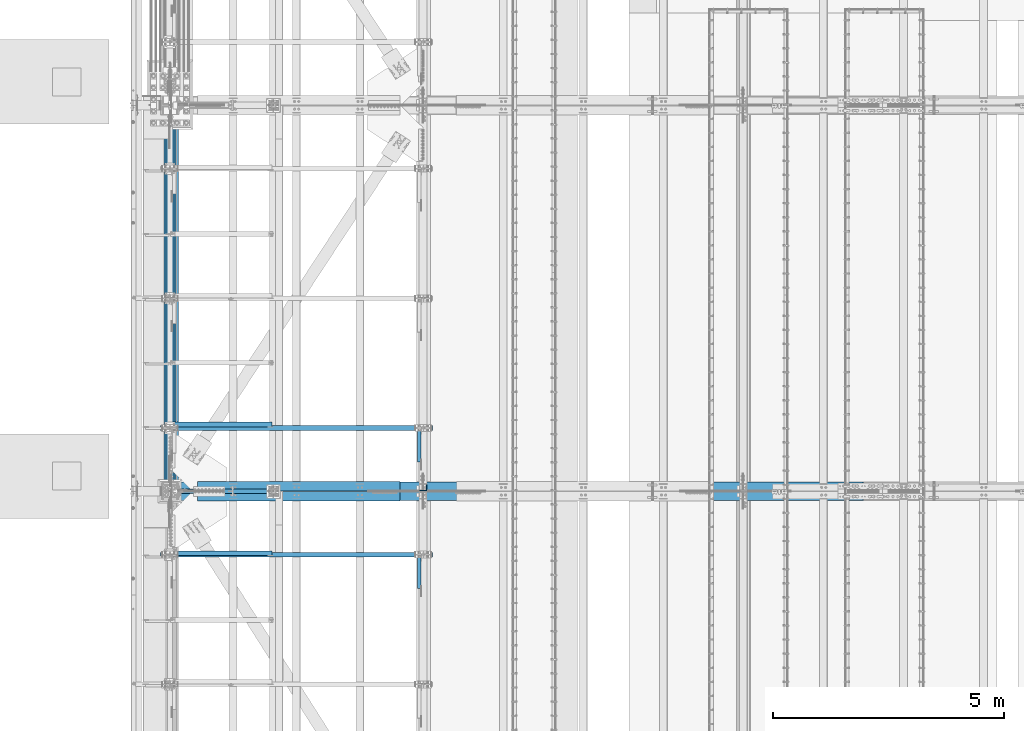
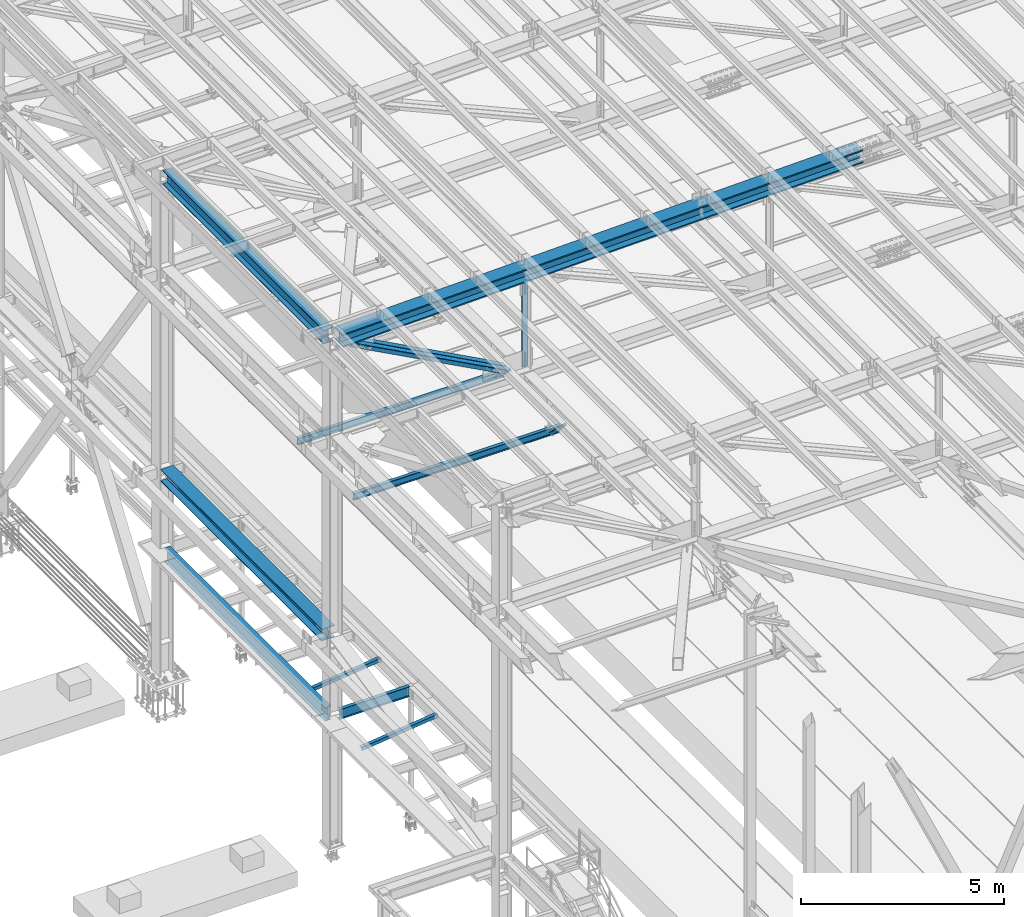
# One storey, part 1809 of 3843: 10 beams, 4 members, 14 elements without a shape of their own.
"""IFC2X3 building model written with IfcOpenShell, lengths in millimetres."""

from ifc_helpers import new_model, si_unit, frame, origin_with_axes, place, context, subcontext, project, spatial, faceted_brep, material, type_object, element, aggregate, save


model = new_model("IFC2X3")

# Units and contexts
model_context = context("Model", 3, precision=1e-05, world=origin_with_axes())
body_context = subcontext(model_context, "Body", "Model", "MODEL_VIEW")
ifc_project = project(units=[si_unit("LENGTHUNIT", "METRE", prefix="MILLI"), si_unit("AREAUNIT", "SQUARE_METRE"), si_unit("VOLUMEUNIT", "CUBIC_METRE"), si_unit("MASSUNIT", "GRAM", prefix="KILO"), si_unit("TIMEUNIT", "SECOND"), si_unit("PLANEANGLEUNIT", "RADIAN"), si_unit("SOLIDANGLEUNIT", "STERADIAN"), si_unit("THERMODYNAMICTEMPERATUREUNIT", "DEGREE_CELSIUS"), si_unit("LUMINOUSINTENSITYUNIT", "LUMEN")], contexts=[model_context])

# Site, building, storey
site_placement = place(None, origin_with_axes())
site = spatial("IfcSite", under=ifc_project, at=site_placement, CompositionType="ELEMENT")
building_placement = place(site_placement, origin_with_axes())
building = spatial("IfcBuilding", under=site, at=building_placement, Name="Undefined", CompositionType="ELEMENT")
storey_placement = place(building_placement, origin_with_axes())
storey = spatial("IfcBuildingStorey", under=building, at=storey_placement, Name="Undefined", CompositionType="ELEMENT", Elevation=0.0)

# Assembly, beam
assembly_1_placement = place(storey_placement, origin_with_axes())
assembly_1 = element("IfcElementAssembly", 1, at=assembly_1_placement, inside=storey, Name="ANGLE", AssemblyPlace="NOTDEFINED", PredefinedType="RIGID_FRAME")
ifc_material_1 = material(Name="STEEL/A572-50")
beam_type_1 = type_object("IfcBeamType", Name="L4X4X3/8", PredefinedType="NOTDEFINED")
beam_1_placement = place(assembly_1_placement, frame((38788.5093206542, 40863.341406, 33960.1419503901), z_axis=(0.0, 1.0, 0.0), x_axis=(-0.993268693078032, 0.0, -0.115833084009098)))
beam_1 = element("IfcBeam", 2, at=beam_1_placement, type_object=beam_type_1, material=ifc_material_1, Name="ANGLE", ObjectType="L4X4X3/8", context=body_context, shape_type="Brep", body=[
    faceted_brep([(0.0, 50.8000000000029, -50.8000000000029), (0.0, 50.8000000000029, 50.8000000000029), (2192.8104802954, 50.7999999940694, 50.8000000000029), (2192.8104802954, 50.7999999940694, -50.8000000000029), (0.0, 41.2750000000015, 50.8000000000029), (2192.81048029537, 41.2749999940788, 50.8000000000029), (0.0, 41.2749999999942, -41.2750000000015), (2192.81048029537, 41.2749999940788, -41.2750000000015), (0.0, -50.8000000000029, -41.2750000000015), (2192.81048029512, -50.8000000058528, -41.2750000000015), (0.0, -50.8000000000029, -50.8000000000029), (2192.81048029512, -50.8000000058528, -50.8000000000029)], [[[0, 1, 2, 3]], [[1, 4, 5, 2]], [[4, 6, 7, 5]], [[6, 8, 9, 7]], [[8, 10, 11, 9]], [[10, 0, 3, 11]], [[5, 7, 9, 11, 3, 2]], [[10, 8, 6, 4, 1, 0]]]),
])
aggregate(assembly_1, [beam_1])

assembly_2_placement = place(storey_placement, origin_with_axes())
assembly_2 = element("IfcElementAssembly", 3, at=assembly_2_placement, inside=storey, Name="ANGLE", AssemblyPlace="NOTDEFINED", PredefinedType="RIGID_FRAME")
beam_2_placement = place(assembly_2_placement, frame((38788.5093206542, 43648.808594, 33960.1419503901), z_axis=(0.0, 1.0, 0.0), x_axis=(-0.993268693078032, 0.0, -0.115833084009098)))
beam_2 = element("IfcBeam", 4, at=beam_2_placement, type_object=beam_type_1, material=ifc_material_1, Name="ANGLE", ObjectType="L4X4X3/8", context=body_context, shape_type="Brep", body=[
    faceted_brep([(0.0, 50.8000000000029, -50.8000000000029), (0.0, 50.8000000000029, 50.8000000000029), (2192.8104802954, 50.7999999940694, 50.8000000000029), (2192.8104802954, 50.7999999940694, -50.8000000000029), (0.0, 41.2750000000015, 50.8000000000029), (2192.81048029537, 41.2749999940788, 50.8000000000029), (0.0, 41.2749999999942, -41.2750000000015), (2192.81048029537, 41.2749999940788, -41.2750000000015), (0.0, -50.8000000000029, -41.2750000000015), (2192.81048029512, -50.8000000058528, -41.2750000000015), (0.0, -50.8000000000029, -50.8000000000029), (2192.81048029512, -50.8000000058528, -50.8000000000029)], [[[0, 1, 2, 3]], [[1, 4, 5, 2]], [[4, 6, 7, 5]], [[6, 8, 9, 7]], [[8, 10, 11, 9]], [[10, 0, 3, 11]], [[5, 7, 9, 11, 3, 2]], [[10, 8, 6, 4, 1, 0]]]),
])
aggregate(assembly_2, [beam_2])

# Assembly, member
assembly_3_placement = place(storey_placement, origin_with_axes())
assembly_3 = element("IfcElementAssembly", 5, at=assembly_3_placement, inside=storey, Name="ANGLE", AssemblyPlace="NOTDEFINED", PredefinedType="RIGID_FRAME")
member_type_1 = type_object("IfcMemberType", Name="L3X3X1/4", PredefinedType="NOTDEFINED")
member_1_placement = place(assembly_3_placement, frame((41973.5, 39860.4569280365, 42270.4430719635), z_axis=(0.0, -0.707106781186548, -0.707106781186548), x_axis=(5.70000238222118e-08, 0.707106781186546, -0.707106781186546)))
member_1 = element("IfcMember", 6, at=member_1_placement, type_object=member_type_1, material=ifc_material_1, Name="ANGLE", ObjectType="L3X3X1/4", context=body_context, shape_type="Brep", body=[
    faceted_brep([(1288.84678778952, -38.0999999999985, -31.7499999999272), (1288.84678778953, -38.0999999999985, -38.0999999999112), (1288.84678778953, 38.0999999999985, -38.0999999999112), (1288.84678778952, 38.0999999999985, 38.099999999904), (1288.84678778952, 31.75, 38.099999999904), (1288.84678778952, 31.75, -31.7499999999272), (298.246787789525, 31.75, 38.099999999904), (298.246787789525, 31.75, -31.7499999999272), (298.246787789525, -38.0999999999985, -31.7499999999272), (298.246787789521, -38.0999999999985, -38.0999999999112), (298.246787789521, 38.0999999999985, -38.0999999999112), (298.246787789525, 38.0999999999985, 38.099999999904)], [[[0, 1, 2, 3, 4, 5]], [[5, 4, 6, 7]], [[0, 5, 7, 8]], [[1, 0, 8, 9]], [[2, 1, 9, 10]], [[3, 2, 10, 11]], [[4, 3, 11, 6]], [[10, 9, 8, 7, 6, 11]]]),
])
aggregate(assembly_3, [member_1])

assembly_4_placement = place(storey_placement, origin_with_axes())
assembly_4 = element("IfcElementAssembly", 7, at=assembly_4_placement, inside=storey, Name="ANGLE", AssemblyPlace="NOTDEFINED", PredefinedType="RIGID_FRAME")
member_2_placement = place(assembly_4_placement, frame((41973.5, 42576.5293455559, 42297.5706544441), z_axis=(0.0, -0.707106781186548, -0.707106781186548), x_axis=(5.70000238222118e-08, 0.707106781186546, -0.707106781186546)))
member_2 = element("IfcMember", 8, at=member_2_placement, type_object=member_type_1, material=ifc_material_1, Name="ANGLE", ObjectType="L3X3X1/4", context=body_context, shape_type="Brep", body=[
    faceted_brep([(1327.21098284778, -38.0999999999985, -31.74999999992), (1327.21098284778, -38.0999999999985, -38.0999999999112), (1327.21098284778, 38.0999999999985, -38.0999999999112), (1327.21098284777, 38.0999999999985, 38.0999999999112), (1327.21098284777, 31.75, 38.0999999999112), (1327.21098284778, 31.75, -31.74999999992), (336.610982847711, 31.75, 38.0999999999112), (336.610982847719, 31.75, -31.74999999992), (336.610982847719, -38.0999999999985, -31.74999999992), (336.610982847715, -38.0999999999985, -38.099999999904), (336.610982847715, 38.0999999999985, -38.099999999904), (336.610982847711, 38.0999999999985, 38.0999999999112)], [[[0, 1, 2, 3, 4, 5]], [[5, 4, 6, 7]], [[0, 5, 7, 8]], [[1, 0, 8, 9]], [[2, 1, 9, 10]], [[3, 2, 10, 11]], [[4, 3, 11, 6]], [[10, 9, 8, 7, 6, 11]]]),
])
aggregate(assembly_4, [member_2])

# Assembly, beam
assembly_5_placement = place(storey_placement, origin_with_axes())
assembly_5 = element("IfcElementAssembly", 9, at=assembly_5_placement, inside=storey, Name="BEAM", AssemblyPlace="NOTDEFINED", PredefinedType="RIGID_FRAME")
ifc_material_2 = material(Name="STEEL/A992")
beam_type_2 = type_object("IfcBeamType", Name="W8X13", PredefinedType="NOTDEFINED")
beam_3_placement = place(assembly_5_placement, frame((36372.8, 40830.5, 41402.0), z_axis=(0.0, 0.0, 1.0), x_axis=(1.0, 0.0, 0.0)))
beam_3 = element("IfcBeam", 10, at=beam_3_placement, type_object=beam_type_2, material=ifc_material_2, Name="BEAM", ObjectType="W8X13", context=body_context, shape_type="Brep", body=[
    faceted_brep([(0.0, 50.7999999999993, -101.599999999999), (0.0, 50.7999999999993, -95.25), (5892.8, 50.7999999999993, -95.25), (5892.8, 50.7999999999993, -101.599999999999), (0.0, 3.17499999999927, -95.25), (5892.8, 3.17499999999927, -95.25), (-2.44140610448085e-05, 3.17500000000291, 95.2499999999927), (5892.8, 3.17499999999927, 95.25), (0.0, 50.7999999999993, 95.25), (5892.8, 50.7999999999993, 95.25), (0.0, 50.7999999999993, 101.599999999999), (5892.8, 50.7999999999993, 101.599999999999), (0.0, -50.7999999999993, 101.599999999999), (5892.8, -50.7999999999993, 101.599999999999), (0.0, -50.7999999999993, 95.25), (5892.8, -50.7999999999993, 95.25), (0.0, -3.17499999999927, 95.25), (5892.8, -3.17499999999927, 95.25), (0.0, -3.17499999999927, -95.25), (5892.8, -3.17499999999927, -95.25), (0.0, -50.7999999999993, -95.25), (5892.8, -50.7999999999993, -95.25), (0.0, -50.7999999999993, -101.599999999999), (5892.8, -50.7999999999993, -101.599999999999)], [[[0, 1, 2, 3]], [[1, 4, 5, 2]], [[4, 6, 7, 5]], [[6, 8, 9, 7]], [[8, 10, 11, 9]], [[10, 12, 13, 11]], [[12, 14, 15, 13]], [[14, 16, 17, 15]], [[16, 18, 19, 17]], [[18, 20, 21, 19]], [[20, 22, 23, 21]], [[22, 0, 3, 23]], [[5, 7, 9, 11, 13, 15, 17, 19, 21, 23, 3, 2]], [[22, 20, 18, 16, 14, 12, 10, 8, 6, 4, 1, 0]]]),
])
aggregate(assembly_5, [beam_3])

assembly_6_placement = place(storey_placement, origin_with_axes())
assembly_6 = element("IfcElementAssembly", 11, at=assembly_6_placement, inside=storey, Name="BEAM", AssemblyPlace="NOTDEFINED", PredefinedType="RIGID_FRAME")
beam_4_placement = place(assembly_6_placement, frame((36372.8, 43573.7, 41402.0), z_axis=(0.0, 0.0, 1.0), x_axis=(1.0, 0.0, 0.0)))
beam_4 = element("IfcBeam", 12, at=beam_4_placement, type_object=beam_type_2, material=ifc_material_2, Name="BEAM", ObjectType="W8X13", context=body_context, shape_type="Brep", body=[
    faceted_brep([(0.0, 50.7999999999993, -101.599999999999), (0.0, 50.7999999999993, -95.25), (5892.8, 50.7999999999993, -95.25), (5892.8, 50.7999999999993, -101.599999999999), (0.0, 3.17499999999927, -95.25), (5892.8, 3.17499999999927, -95.25), (-2.44140610448085e-05, 3.17500000000291, 95.2499999999927), (5892.8, 3.17499999999927, 95.25), (0.0, 50.7999999999993, 95.25), (5892.8, 50.7999999999993, 95.25), (0.0, 50.7999999999993, 101.599999999999), (5892.8, 50.7999999999993, 101.599999999999), (0.0, -50.7999999999993, 101.599999999999), (5892.8, -50.7999999999993, 101.599999999999), (0.0, -50.7999999999993, 95.25), (5892.8, -50.7999999999993, 95.25), (0.0, -3.17499999999927, 95.25), (5892.8, -3.17499999999927, 95.25), (0.0, -3.17499999999927, -95.25), (5892.8, -3.17499999999927, -95.25), (0.0, -50.7999999999993, -95.25), (5892.8, -50.7999999999993, -95.25), (0.0, -50.7999999999993, -101.599999999999), (5892.8, -50.7999999999993, -101.599999999999)], [[[0, 1, 2, 3]], [[1, 4, 5, 2]], [[4, 6, 7, 5]], [[6, 8, 9, 7]], [[8, 10, 11, 9]], [[10, 12, 13, 11]], [[12, 14, 15, 13]], [[14, 16, 17, 15]], [[16, 18, 19, 17]], [[18, 20, 21, 19]], [[20, 22, 23, 21]], [[22, 0, 3, 23]], [[5, 7, 9, 11, 13, 15, 17, 19, 21, 23, 3, 2]], [[22, 20, 18, 16, 14, 12, 10, 8, 6, 4, 1, 0]]]),
])
aggregate(assembly_6, [beam_4])

assembly_7_placement = place(storey_placement, origin_with_axes())
assembly_7 = element("IfcElementAssembly", 13, at=assembly_7_placement, inside=storey, Name="BEAM", AssemblyPlace="NOTDEFINED", PredefinedType="RIGID_FRAME")
beam_type_3 = type_object("IfcBeamType", Name="W14X193", PredefinedType="NOTDEFINED")
beam_5_placement = place(assembly_7_placement, frame((36581.1927673553, 42202.1, 45221.5968545871), z_axis=(-0.0251104770065213, 0.0, 0.999684682259614), x_axis=(0.99968468698203, 0.0, 0.0251102889995484)))
beam_5 = element("IfcBeam", 14, at=beam_5_placement, type_object=beam_type_3, material=ifc_material_2, Name="BEAM", ObjectType="W14X193", context=body_context, shape_type="Brep", body=[
    faceted_brep([(12012.6309710702, 11.1125000000029, 163.391995177728), (12012.6309710702, 200.025000000001, 163.391995177728), (13514.2350328195, 200.025000000001, 162.055596753664), (13514.2350328195, 11.1125000000029, 162.055596753664), (10511.0266180469, 11.1125000000029, 164.346565542677), (10511.0266180469, 200.025000000001, 164.346565542677), (9009.42207084113, 11.1125000000029, 164.919307789831), (9009.42207084113, 200.025000000001, 164.919307789831), (7507.81742654402, 11.1125000000029, 165.110221879142), (7507.81742654402, 200.025000000001, 165.110221879142), (6006.21278224691, 11.1125000000029, 164.919307800374), (6006.21278224691, 200.025000000001, 164.919307800374), (4504.60823504109, 11.1125000000029, 164.346565563763), (4504.60823504109, 200.025000000001, 164.346565563763), (3003.00388201789, 11.1125000000029, 163.391995209349), (3003.00388201789, 200.025000000001, 163.391995209349), (1501.39982026855, 11.1125000000029, 162.055596795835), (1501.39982026855, 200.025000000001, 162.055596795835), (195.750703406564, 11.1125000000029, 160.561593549821), (195.750703406564, 200.025000000001, 160.561593549821), (12012.3863472874, 200.025000000001, -157.282911518283), (12012.3863472874, 11.1125000000029, -157.282911518283), (13513.9088678008, 11.1125000000029, -158.61923737223), (13513.9088678008, 200.025000000001, -158.61923737223), (10510.8635355159, 200.025000000001, -156.328392989126), (10510.8635355159, 11.1125000000029, -156.328392989126), (9009.34052957242, 200.025000000001, -155.75568184346), (9009.34052957242, 11.1125000000029, -155.75568184346), (7507.8174265429, 200.025000000001, -155.564778121312), (7507.8174265429, 11.1125000000029, -155.564778121312), (6006.29432351337, 200.025000000001, -155.755681832918), (6006.29432351337, 11.1125000000029, -155.755681832918), (4504.77131756986, 200.025000000001, -156.328392968047), (4504.77131756986, 11.1125000000029, -156.328392968047), (3003.24850579841, 200.025000000001, -157.282911486654), (3003.24850579841, 11.1125000000029, -157.282911486654), (1501.72598528501, 200.025000000001, -158.619237330058), (1501.72598528501, 11.1125000000029, -158.619237330058), (187.695684980397, 200.025000000001, -160.122830836663), (187.695684980397, 11.1125000000029, -160.122830836663), (12012.3584940844, -200.025000000001, -193.79540089456), (12012.3584940844, 200.025000000001, -193.79540089456), (13513.8717301996, 200.025000000001, -195.13171848558), (13513.8717301996, -200.025000000001, -195.13171848558), (10510.8449667129, -200.025000000001, -192.840888267507), (10510.8449667129, 200.025000000001, -192.840888267507), (9009.33124517055, -200.025000000001, -192.268180663086), (9009.33124517055, 200.025000000001, -192.268180663086), (7507.81742654277, -200.025000000001, -192.07727812136), (7507.81742654277, 200.025000000001, -192.07727812136), (6006.303607915, -200.025000000001, -192.268180652551), (6006.303607915, 200.025000000001, -192.268180652551), (4504.78988637264, -200.025000000001, -192.840888246428), (4504.78988637264, 200.025000000001, -192.840888246428), (3003.27635900114, -200.025000000001, -193.795400862931), (3003.27635900114, 200.025000000001, -193.795400862931), (1501.7631228859, -200.025000000001, -195.131718443416), (1501.7631228859, 200.025000000001, -195.131718443416), (186.778529417024, -200.025000000001, -196.636403910379), (186.778529417024, 200.025000000001, -196.636403910379), (12012.3863472874, -11.1125000000029, -157.282911518283), (12012.3863472874, -200.025000000001, -157.282911518283), (13513.9088678008, -200.025000000001, -158.61923737223), (13513.9088678008, -11.1125000000029, -158.61923737223), (10510.8635355159, -11.1125000000029, -156.328392989126), (10510.8635355159, -200.025000000001, -156.328392989126), (9009.34052957242, -11.1125000000029, -155.75568184346), (9009.34052957242, -200.025000000001, -155.75568184346), (7507.8174265429, -11.1125000000029, -155.564778121312), (7507.8174265429, -200.025000000001, -155.564778121312), (6006.29432351337, -11.1125000000029, -155.755681832918), (6006.29432351337, -200.025000000001, -155.755681832918), (4504.77131756986, -11.1125000000029, -156.328392968047), (4504.77131756986, -200.025000000001, -156.328392968047), (3003.24850579841, -11.1125000000029, -157.282911486654), (3003.24850579841, -200.025000000001, -157.282911486654), (1501.72598528501, -11.1125000000029, -158.619237330058), (1501.72598528501, -200.025000000001, -158.619237330058), (187.695684980397, -11.1125000000029, -160.122830836663), (187.695684980397, -200.025000000001, -160.122830836663), (12012.6309710702, -200.025000000001, 163.391995177728), (12012.6309710702, -11.1125000000029, 163.391995177728), (13514.2350328195, -11.1125000000029, 162.055596753664), (13514.2350328195, -200.025000000001, 162.055596753664), (10511.0266180469, -200.025000000001, 164.346565542677), (10511.0266180469, -11.1125000000029, 164.346565542677), (9009.42207084113, -200.025000000001, 164.919307789831), (9009.42207084113, -11.1125000000029, 164.919307789831), (7507.81742654402, -200.025000000001, 165.110221879142), (7507.81742654402, -11.1125000000029, 165.110221879142), (6006.21278224691, -200.025000000001, 164.919307800374), (6006.21278224691, -11.1125000000029, 164.919307800374), (4504.60823504109, -200.025000000001, 164.346565563763), (4504.60823504109, -11.1125000000029, 164.346565563763), (3003.00388201789, -200.025000000001, 163.391995209349), (3003.00388201789, -11.1125000000029, 163.391995209349), (1501.39982026855, -200.025000000001, 162.055596795835), (1501.39982026855, -11.1125000000029, 162.055596795835), (195.750703406564, -200.025000000001, 160.561593549821), (195.750703406564, -11.1125000000029, 160.561593549821), (196.667858969937, -200.025000000001, 197.07516662353), (196.667858969937, 200.025000000001, 197.07516662353), (1501.36268266766, -200.025000000001, 198.568077909178), (1501.36268266766, 200.025000000001, 198.568077909178), (3002.97602881516, -200.025000000001, 199.904484585633), (3002.97602881516, 200.025000000001, 199.904484585633), (4504.58966623832, -200.025000000001, 200.859060842136), (4504.58966623832, 200.025000000001, 200.859060842136), (6006.20349784529, -200.025000000001, 201.431806620007), (6006.20349784529, 200.025000000001, 201.431806620007), (7507.81742654416, -200.025000000001, 201.622721879205), (7507.81742654416, 200.025000000001, 201.622721879205), (9009.43135524302, -200.025000000001, 201.431806609464), (9009.43135524302, 200.025000000001, 201.431806609464), (10511.04518685, -200.025000000001, 200.859060821043), (10511.04518685, 200.025000000001, 200.859060821043), (12012.6588242731, -200.025000000001, 199.904484554012), (12012.6588242731, 200.025000000001, 199.904484554012), (13514.2721704206, -200.025000000001, 198.568077867014), (13514.2721704206, 200.025000000001, 198.568077867014), (15009.535132154, -200.025000000001, 196.857106899901), (15009.535132154, 200.025000000001, 196.857106899901), (15009.4887541494, 200.025000000001, 160.344636359994), (15009.4887541494, 11.1125000000029, 160.344636359994), (15009.0814342832, 11.1125000000029, -160.33010490358), (15009.0814342832, 200.025000000001, -160.33010490358), (15009.0350562786, 200.025000000001, -196.842575443494), (15009.0350562786, -200.025000000001, -196.842575443494), (15009.0814342832, -200.025000000001, -160.33010490358), (15009.0814342832, -11.1125000000029, -160.33010490358), (15009.4887541494, -11.1125000000029, 160.344636359994), (15009.4887541494, -200.025000000001, 160.344636359994)], [[[0, 1, 2, 3]], [[4, 5, 1, 0]], [[6, 7, 5, 4]], [[8, 9, 7, 6]], [[10, 11, 9, 8]], [[12, 13, 11, 10]], [[14, 15, 13, 12]], [[16, 17, 15, 14]], [[17, 16, 18, 19]], [[20, 21, 22, 23]], [[24, 25, 21, 20]], [[26, 27, 25, 24]], [[28, 29, 27, 26]], [[30, 31, 29, 28]], [[32, 33, 31, 30]], [[34, 35, 33, 32]], [[36, 37, 35, 34]], [[37, 36, 38, 39]], [[40, 41, 42, 43]], [[44, 45, 41, 40]], [[46, 47, 45, 44]], [[48, 49, 47, 46]], [[50, 51, 49, 48]], [[52, 53, 51, 50]], [[54, 55, 53, 52]], [[56, 57, 55, 54]], [[57, 56, 58, 59]], [[60, 61, 62, 63]], [[64, 65, 61, 60]], [[66, 67, 65, 64]], [[68, 69, 67, 66]], [[70, 71, 69, 68]], [[72, 73, 71, 70]], [[74, 75, 73, 72]], [[76, 77, 75, 74]], [[77, 76, 78, 79]], [[80, 81, 82, 83]], [[84, 85, 81, 80]], [[86, 87, 85, 84]], [[88, 89, 87, 86]], [[90, 91, 89, 88]], [[92, 93, 91, 90]], [[94, 95, 93, 92]], [[96, 97, 95, 94]], [[97, 96, 98, 99]], [[19, 18, 39, 38, 59, 58, 79, 78, 99, 98, 100, 101]], [[102, 103, 101, 100]], [[103, 102, 104, 105]], [[105, 104, 106, 107]], [[107, 106, 108, 109]], [[109, 108, 110, 111]], [[111, 110, 112, 113]], [[113, 112, 114, 115]], [[115, 114, 116, 117]], [[117, 116, 118, 119]], [[119, 118, 120, 121]], [[2, 1, 5, 7, 9, 11, 13, 15, 17, 19, 101, 103, 105, 107, 109, 111, 113, 115, 117, 119, 121, 122]], [[3, 2, 122, 123]], [[22, 21, 25, 27, 29, 31, 33, 35, 37, 39, 18, 16, 14, 12, 10, 8, 6, 4, 0, 3, 123, 124]], [[23, 22, 124, 125]], [[42, 41, 45, 47, 49, 51, 53, 55, 57, 59, 38, 36, 34, 32, 30, 28, 26, 24, 20, 23, 125, 126]], [[43, 42, 126, 127]], [[62, 61, 65, 67, 69, 71, 73, 75, 77, 79, 58, 56, 54, 52, 50, 48, 46, 44, 40, 43, 127, 128]], [[63, 62, 128, 129]], [[82, 81, 85, 87, 89, 91, 93, 95, 97, 99, 78, 76, 74, 72, 70, 68, 66, 64, 60, 63, 129, 130]], [[83, 82, 130, 131]], [[118, 116, 114, 112, 110, 108, 106, 104, 102, 100, 98, 96, 94, 92, 90, 88, 86, 84, 80, 83, 131, 120]], [[130, 129, 128, 127, 126, 125, 124, 123, 122, 121, 120, 131]]]),
])
aggregate(assembly_7, [beam_5])

# Assembly, member
assembly_8_placement = place(storey_placement, origin_with_axes())
assembly_8 = element("IfcElementAssembly", 15, at=assembly_8_placement, inside=storey, Name="ANGLE", AssemblyPlace="NOTDEFINED", PredefinedType="RIGID_FRAME")
member_type_2 = type_object("IfcMemberType", Name="L8X8X1/2", PredefinedType="NOTDEFINED")
member_3_placement = place(assembly_8_placement, frame((36576.0000000231, 42313.225, 45221.5250000003), z_axis=(-0.473433505968068, 0.0, -0.880829560940585), x_axis=(0.880829560940586, 0.0, -0.473433505968065)))
member_3 = element("IfcMember", 16, at=member_3_placement, type_object=member_type_2, material=ifc_material_1, Name="ANGLE", ObjectType="L8X8X1/2", context=body_context, shape_type="Brep", body=[
    faceted_brep([(624.567129335563, 101.599999999999, -101.599999999737), (624.56712933557, 101.599999999999, 101.600000000552), (5603.56470770663, 101.599999999999, 101.600000003811), (5603.56470770662, 101.599999999999, -101.59999999647), (624.56712933557, 88.9000000000015, 101.600000000552), (5603.56470770663, 88.9000000000015, 101.600000003811), (624.567129335566, 88.9000000000015, -88.8999999997177), (5603.56470770663, 88.9000000000015, -88.8999999964508), (624.567129335566, -101.599999999999, -88.8999999997177), (5603.56470770663, -101.599999999999, -88.8999999964508), (624.567129335563, -101.599999999999, -101.599999999737), (5603.56470770662, -101.599999999999, -101.59999999647)], [[[0, 1, 2, 3]], [[1, 4, 5, 2]], [[4, 6, 7, 5]], [[6, 8, 9, 7]], [[8, 10, 11, 9]], [[10, 0, 3, 11]], [[5, 7, 9, 11, 3, 2]], [[10, 8, 6, 4, 1, 0]]]),
])
aggregate(assembly_8, [member_3])

assembly_9_placement = place(storey_placement, origin_with_axes())
assembly_9 = element("IfcElementAssembly", 17, at=assembly_9_placement, inside=storey, Name="ANGLE", AssemblyPlace="NOTDEFINED", PredefinedType="RIGID_FRAME")
member_4_placement = place(assembly_9_placement, frame((42062.3999984227, 42090.975, 42272.6621292095), z_axis=(-0.473433505968068, 0.0, -0.880829560940585), x_axis=(-0.880829560940586, 0.0, 0.473433505968066)))
member_4 = element("IfcMember", 18, at=member_4_placement, type_object=member_type_2, material=ifc_material_1, Name="ANGLE", ObjectType="L8X8X1/2", context=body_context, shape_type="Brep", body=[
    faceted_brep([(625.109081582948, 101.599999999999, -101.600000000544), (625.109081582952, 101.599999999999, 101.599999999737), (5604.106659954, 101.599999999999, 101.599999996477), (5604.10665995401, 101.599999999999, -101.600000003811), (625.109081582952, 88.9000000000015, 101.599999999737), (5604.106659954, 88.9000000000015, 101.599999996477), (625.109081582948, 88.9000000000015, -88.9000000005253), (5604.106659954, 88.9000000000015, -88.900000003785), (625.109081582948, -101.599999999999, -88.9000000005253), (5604.106659954, -101.599999999999, -88.900000003785), (625.109081582948, -101.599999999999, -101.600000000544), (5604.10665995401, -101.599999999999, -101.600000003811)], [[[0, 1, 2, 3]], [[1, 4, 5, 2]], [[4, 6, 7, 5]], [[6, 8, 9, 7]], [[8, 10, 11, 9]], [[10, 0, 3, 11]], [[5, 7, 9, 11, 3, 2]], [[10, 8, 6, 4, 1, 0]]]),
])
aggregate(assembly_9, [member_4])

# Assembly, beam
assembly_10_placement = place(storey_placement, origin_with_axes())
assembly_10 = element("IfcElementAssembly", 19, at=assembly_10_placement, inside=storey, Name="ANGLE", AssemblyPlace="NOTDEFINED", PredefinedType="RIGID_FRAME")
beam_type_4 = type_object("IfcBeamType", Name="L6X6X1/2", PredefinedType="NOTDEFINED")
beam_6_placement = place(assembly_10_placement, frame((42062.4, 42287.8249999998, 45363.6585973172), z_axis=(-1.0, 0.0, 0.0), x_axis=(0.0, 0.0, -1.0)))
beam_6 = element("IfcBeam", 20, at=beam_6_placement, type_object=beam_type_4, material=ifc_material_1, Name="ANGLE", ObjectType="L6X6X1/2", context=body_context, shape_type="Brep", body=[
    faceted_brep([(225.438242720811, 76.1999999999971, -76.2000000007174), (225.438242720811, 76.1999999999971, 76.1999999992768), (2881.02688589013, 76.1999999999971, 76.1999999908003), (2881.02688589013, 76.1999999999971, -76.2000000092012), (225.438242720811, 63.5, 76.1999999992768), (2881.02688589013, 63.5, 76.1999999908003), (225.438242720804, 63.5, -63.5000000007203), (2881.02688589012, 63.5, -63.5000000091968), (225.438242720804, -76.1999999999971, -63.5000000007203), (2881.02688589012, -76.1999999999971, -63.5000000091968), (225.438242720811, -76.1999999999971, -76.2000000007174), (2881.02688589013, -76.1999999999971, -76.2000000092012)], [[[0, 1, 2, 3]], [[1, 4, 5, 2]], [[4, 6, 7, 5]], [[6, 8, 9, 7]], [[8, 10, 11, 9]], [[10, 0, 3, 11]], [[5, 7, 9, 11, 3, 2]], [[10, 8, 6, 4, 1, 0]]]),
])
aggregate(assembly_10, [beam_6])

assembly_11_placement = place(storey_placement, origin_with_axes())
assembly_11 = element("IfcElementAssembly", 21, at=assembly_11_placement, inside=storey, Name="BEAM", AssemblyPlace="NOTDEFINED", PredefinedType="RIGID_FRAME")
beam_type_5 = type_object("IfcBeamType", Name="W16X67", PredefinedType="NOTDEFINED")
beam_7_placement = place(assembly_11_placement, frame((36576.0000000231, 42202.1, 45210.4125000003), z_axis=(0.0, 0.0, 1.0), x_axis=(0.0, 1.0, 0.0)))
beam_7 = element("IfcBeam", 22, at=beam_7_placement, type_object=beam_type_5, material=ifc_material_2, Name="BEAM", ObjectType="W16X67", context=body_context, shape_type="Brep", body=[
    faceted_brep([(198.437499999989, -130.175000000003, -207.962500000001), (198.437499999989, 130.175000000003, -207.962500000001), (8143.87500000003, 130.175000000003, -207.962500000001), (8143.87500000003, -130.175000000003, -207.962500000001), (198.437499999989, -130.175000000003, -190.5), (198.437499999989, -4.76249999999709, -190.5), (198.4375, -4.76249999999709, -142.027499865253), (198.4375, -4.76249999999709, 176.952500133215), (198.437499999989, -4.76249999999709, 190.5), (198.437499999989, -130.175000000003, 190.5), (198.437499999989, -130.175000000003, 207.962500000001), (198.437499999989, 130.175000000003, 207.962500000001), (198.437499999989, 130.175000000003, 190.5), (198.437499999989, 4.76249999999709, 190.5), (198.437499999989, 4.76249999999709, -190.5), (198.437499999989, 130.175000000003, -190.5), (8143.87500000003, -130.175000000003, -190.5), (8143.87500000003, -4.76249999999709, -190.5), (8143.87500000003, -4.76249999999709, -142.02750001238), (8143.87500000003, -4.76249999999709, 176.952499987616), (8143.87500000003, -4.76249999999709, 190.5), (8143.87500000003, -130.175000000003, 190.5), (8143.87500000003, -130.175000000003, 207.962500000001), (8143.87500000003, 130.175000000003, 207.962500000001), (8143.87500000003, 130.175000000003, 190.5), (8143.87500000003, 4.76249999999709, 190.5), (8143.87500000003, 4.76249999999709, -190.5), (8143.87500000003, 130.175000000003, -190.5)], [[[0, 1, 2, 3]], [[0, 4, 5, 6, 7, 8, 9, 10, 11, 12, 13, 14, 15, 1]], [[5, 4, 16, 17]], [[8, 7, 6, 5, 17, 18, 19, 20]], [[9, 8, 20, 21]], [[10, 9, 21, 22]], [[11, 10, 22, 23]], [[12, 11, 23, 24]], [[13, 12, 24, 25]], [[14, 13, 25, 26]], [[15, 14, 26, 27]], [[1, 15, 27, 2]], [[26, 25, 24, 23, 22, 21, 20, 19, 18, 17, 16, 3, 2, 27]], [[4, 0, 3, 16]]]),
])
aggregate(assembly_11, [beam_7])

assembly_12_placement = place(storey_placement, origin_with_axes())
assembly_12 = element("IfcElementAssembly", 23, at=assembly_12_placement, inside=storey, Name="BEAM", AssemblyPlace="NOTDEFINED", PredefinedType="RIGID_FRAME")
beam_type_6 = type_object("IfcBeamType", Name="W16X40", PredefinedType="NOTDEFINED")
beam_8_placement = place(assembly_12_placement, frame((36576.0, 42202.1, 33832.8), z_axis=(0.0, 0.0, 1.0), x_axis=(0.0, 1.0, 0.0)))
beam_8 = element("IfcBeam", 24, at=beam_8_placement, type_object=beam_type_6, material=ifc_material_2, Name="BEAM", ObjectType="W16X40", context=body_context, shape_type="Brep", body=[
    faceted_brep([(198.4375, -88.9000000000015, -203.199999999997), (198.4375, 88.9000000000015, -203.199999999997), (8143.87499999999, 88.9000000000015, -203.199999999997), (8143.87499999999, -88.9000000000015, -203.199999999997), (198.4375, -88.9000000000015, -190.5), (198.4375, -3.96875, -190.5), (198.4375, -3.96875, -140.440014546963), (198.4375, -3.96875, 165.839999999997), (198.4375, -3.96875, 190.5), (198.4375, -88.9000000000015, 190.5), (198.4375, -88.9000000000015, 203.199999999997), (198.4375, 88.9000000000015, 203.199999999997), (198.4375, 88.9000000000015, 190.5), (198.4375, 3.96875, 190.5), (198.4375, 3.96875, -190.5), (198.4375, 88.9000000000015, -190.5), (8143.87499999999, -88.9000000000015, -190.5), (8143.87499999999, -3.96875, -190.5), (8143.87499999999, -3.96875, -140.440014362968), (8143.87499999999, -3.96875, 165.839999999997), (8143.87499999999, -3.96875, 190.5), (8143.87499999999, -88.9000000000015, 190.5), (8143.87499999999, -88.9000000000015, 203.199999999997), (8143.87499999999, 88.9000000000015, 203.199999999997), (8143.87499999999, 88.9000000000015, 190.5), (8143.87499999999, 3.96875, 190.5), (8143.87499999999, 3.96875, -190.5), (8143.87499999999, 88.9000000000015, -190.5)], [[[0, 1, 2, 3]], [[0, 4, 5, 6, 7, 8, 9, 10, 11, 12, 13, 14, 15, 1]], [[5, 4, 16, 17]], [[8, 7, 6, 5, 17, 18, 19, 20]], [[9, 8, 20, 21]], [[10, 9, 21, 22]], [[11, 10, 22, 23]], [[12, 11, 23, 24]], [[13, 12, 24, 25]], [[14, 13, 25, 26]], [[15, 14, 26, 27]], [[1, 15, 27, 2]], [[26, 25, 24, 23, 22, 21, 20, 19, 18, 17, 16, 3, 2, 27]], [[4, 0, 3, 16]]]),
])
aggregate(assembly_12, [beam_8])

assembly_13_placement = place(storey_placement, origin_with_axes())
assembly_13 = element("IfcElementAssembly", 25, at=assembly_13_placement, inside=storey, Name="BEAM", AssemblyPlace="NOTDEFINED", PredefinedType="RIGID_FRAME")
beam_type_7 = type_object("IfcBeamType", Name="W14X90", PredefinedType="NOTDEFINED")
beam_9_placement = place(assembly_13_placement, frame((36576.0, 42202.1, 36258.5), z_axis=(0.0, 0.0, 1.0), x_axis=(0.0, 1.0, 0.0)))
beam_9 = element("IfcBeam", 26, at=beam_9_placement, type_object=beam_type_7, material=ifc_material_2, Name="BEAM", ObjectType="W14X90", context=body_context, shape_type="Brep", body=[
    faceted_brep([(198.4375, 184.150000000001, -177.800000000003), (198.4375, 184.150000000001, -160.337500000001), (8143.87500000002, 184.150000000001, -160.337500000001), (8143.87500000002, 184.150000000001, -177.800000000003), (198.4375, 5.55625000000146, -160.337500000001), (8143.87500000002, 5.55625000000146, -160.337500000001), (198.4375, 5.55625000000146, 160.337500000001), (8143.87500000002, 5.55625000000146, 160.337500000001), (198.4375, 184.150000000001, 160.337500000001), (8143.87500000002, 184.150000000001, 160.337500000001), (198.4375, 184.150000000001, 177.800000000003), (8143.87500000002, 184.150000000001, 177.800000000003), (198.4375, -184.150000000001, 177.800000000003), (8143.87500000002, -184.150000000001, 177.800000000003), (198.4375, -184.150000000001, 160.337500000001), (8143.87500000002, -184.150000000001, 160.337500000001), (198.4375, -5.55625000000146, 160.337500000001), (8143.87500000002, -5.55625000000146, 160.337500000001), (198.4375, -5.55625000000146, -160.337500000001), (8143.87500000002, -5.55625000000146, -160.337500000001), (198.4375, -184.150000000001, -160.337500000001), (8143.87500000002, -184.150000000001, -160.337500000001), (198.4375, -184.150000000001, -177.800000000003), (8143.87500000002, -184.150000000001, -177.800000000003)], [[[0, 1, 2, 3]], [[1, 4, 5, 2]], [[4, 6, 7, 5]], [[6, 8, 9, 7]], [[8, 10, 11, 9]], [[10, 12, 13, 11]], [[12, 14, 15, 13]], [[14, 16, 17, 15]], [[16, 18, 19, 17]], [[18, 20, 21, 19]], [[20, 22, 23, 21]], [[22, 0, 3, 23]], [[5, 7, 9, 11, 13, 15, 17, 19, 21, 23, 3, 2]], [[22, 20, 18, 16, 14, 12, 10, 8, 6, 4, 1, 0]]]),
])
aggregate(assembly_13, [beam_9])

assembly_14_placement = place(storey_placement, origin_with_axes())
assembly_14 = element("IfcElementAssembly", 27, at=assembly_14_placement, inside=storey, Name="BEAM", AssemblyPlace="NOTDEFINED", PredefinedType="RIGID_FRAME")
beam_type_8 = type_object("IfcBeamType", Name="W12X14", PredefinedType="NOTDEFINED")
beam_10_placement = place(assembly_14_placement, frame((36576.0, 42202.1, 33885.1875), z_axis=(0.0, 0.0, 1.0), x_axis=(1.0, 0.0, 0.0)))
beam_10 = element("IfcBeam", 28, at=beam_10_placement, type_object=beam_type_8, material=ifc_material_2, Name="BEAM", ObjectType="W12X14", context=body_context, shape_type="Brep", body=[
    faceted_brep([(196.849999999999, -50.8000000000029, -150.8125), (196.849999999999, 50.8000000000029, -150.8125), (2181.225, 50.8000000000029, -150.8125), (2181.225, -50.8000000000029, -150.8125), (196.849999999973, -50.8000000000029, -144.462500000001), (196.849999999999, -2.38125000000582, -144.462500000001), (196.849999999999, -2.38125000000582, 144.462500000001), (196.849999999973, -50.8000000000029, 144.462500000001), (196.849999999999, -50.8000000000029, 150.8125), (196.849999999999, 50.8000000000029, 150.8125), (196.849999999973, 50.8000000000029, 144.462500000001), (196.849999999999, 2.38125000000582, 144.462500000001), (196.849999999999, 2.38125000000582, -144.462500000001), (196.849999999973, 50.8000000000029, -144.462500000001), (2181.225, -50.8000000000029, -144.462500000001), (2181.225, -2.38125000000582, -144.462500000001), (2181.225, -2.38125000000582, 144.462500000001), (2181.225, -50.8000000000029, 144.462500000001), (2181.225, -50.8000000000029, 150.8125), (2181.225, 50.8000000000029, 150.8125), (2181.225, 50.8000000000029, 144.462500000001), (2181.225, 2.38125000000582, 144.462500000001), (2181.225, 2.38125000000582, -144.462500000001), (2181.225, 50.8000000000029, -144.462500000001)], [[[0, 1, 2, 3]], [[0, 4, 5, 6, 7, 8, 9, 10, 11, 12, 13, 1]], [[5, 4, 14, 15]], [[6, 5, 15, 16]], [[7, 6, 16, 17]], [[8, 7, 17, 18]], [[9, 8, 18, 19]], [[10, 9, 19, 20]], [[11, 10, 20, 21]], [[12, 11, 21, 22]], [[13, 12, 22, 23]], [[1, 13, 23, 2]], [[22, 21, 20, 19, 18, 17, 16, 15, 14, 3, 2, 23]], [[4, 0, 3, 14]]]),
])
aggregate(assembly_14, [beam_10])

save(model, "model.ifc")
